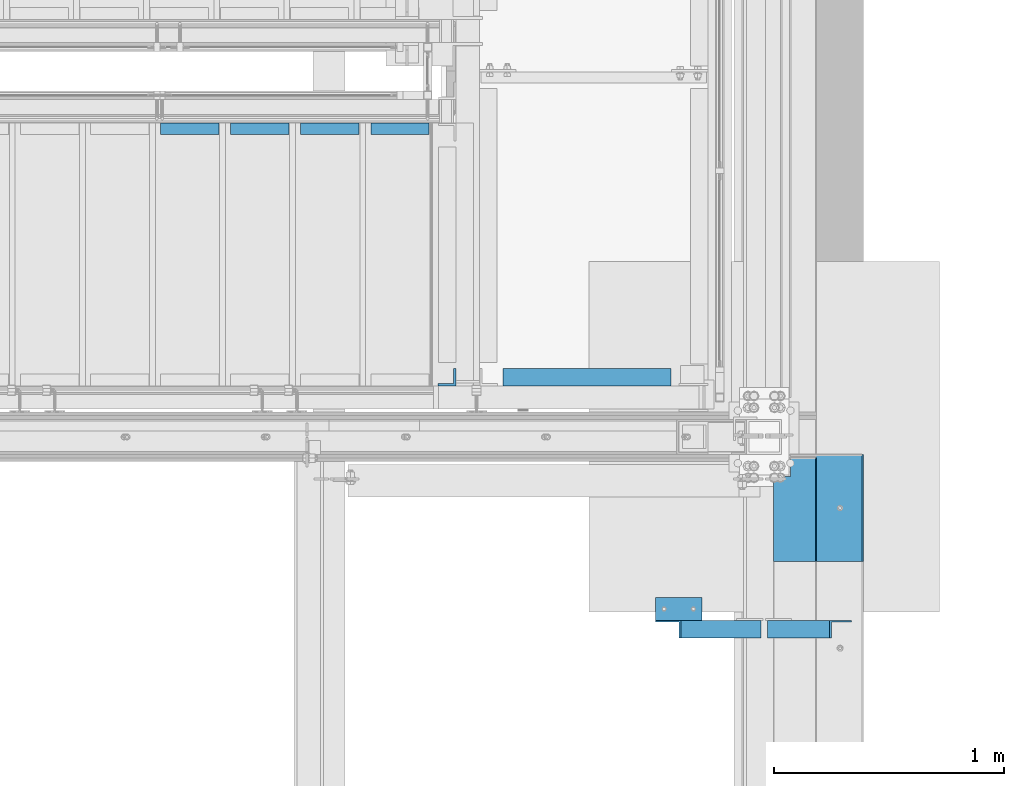
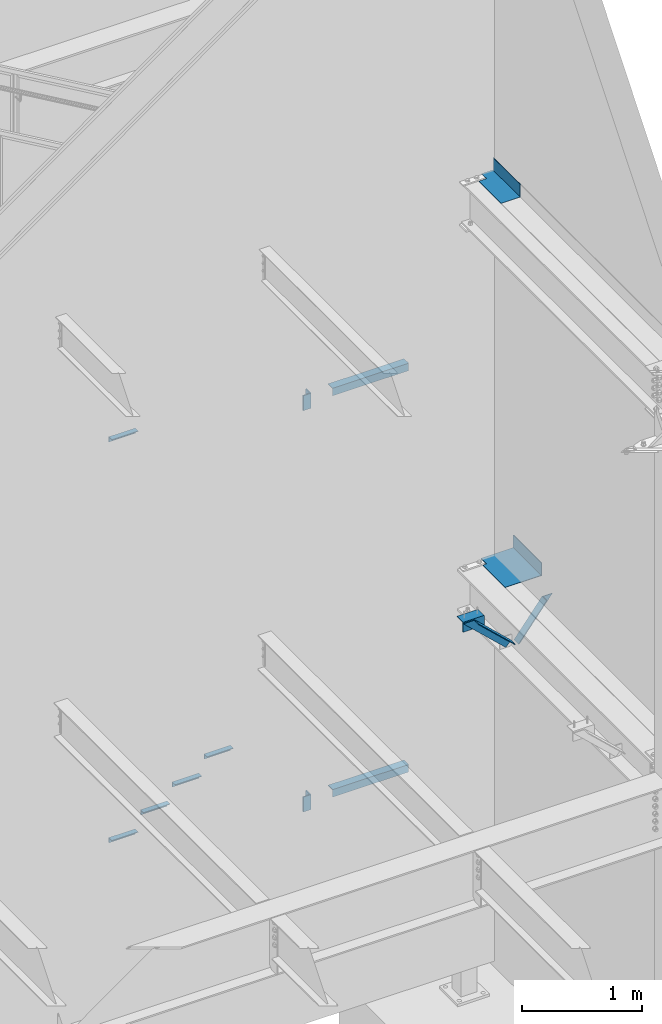
# One storey, part 918 of 1179: 12 beams, 2 members, 7 elements without a shape of their own.
"""IFC2X3 building model written with IfcOpenShell, lengths in millimetres."""

from ifc_helpers import new_model, si_unit, frame, origin_with_axes, place, context, subcontext, project, spatial, faceted_brep, material, type_object, element, aggregate, save


model = new_model("IFC2X3")

# Units and contexts
model_context = context("Model", 3, precision=1e-05, world=origin_with_axes())
body_context = subcontext(model_context, "Body", "Model", "MODEL_VIEW")
ifc_project = project(units=[si_unit("LENGTHUNIT", "METRE", prefix="MILLI"), si_unit("AREAUNIT", "SQUARE_METRE"), si_unit("VOLUMEUNIT", "CUBIC_METRE"), si_unit("MASSUNIT", "GRAM", prefix="KILO"), si_unit("TIMEUNIT", "SECOND"), si_unit("PLANEANGLEUNIT", "RADIAN"), si_unit("SOLIDANGLEUNIT", "STERADIAN"), si_unit("THERMODYNAMICTEMPERATUREUNIT", "DEGREE_CELSIUS"), si_unit("LUMINOUSINTENSITYUNIT", "LUMEN")], contexts=[model_context])

# Site, building, storey
site_placement = place(None, origin_with_axes())
site = spatial("IfcSite", under=ifc_project, at=site_placement, CompositionType="ELEMENT")
building_placement = place(site_placement, origin_with_axes())
building = spatial("IfcBuilding", under=site, at=building_placement, Name="Undefined", CompositionType="ELEMENT")
storey_placement = place(building_placement, origin_with_axes())
storey = spatial("IfcBuildingStorey", under=building, at=storey_placement, Name="Undefined", CompositionType="ELEMENT", Elevation=0.0)

# Assembly, beam
assembly_1_placement = place(storey_placement, origin_with_axes())
assembly_1 = element("IfcElementAssembly", 1, at=assembly_1_placement, inside=storey, Name="STAIR", AssemblyPlace="NOTDEFINED", PredefinedType="RIGID_FRAME")
ifc_material = material(Name="STEEL/A36")
beam_type_1 = type_object("IfcBeamType", Name="L2X2X3/16", PredefinedType="NOTDEFINED")
beam_1_placement = place(assembly_1_placement, frame((21682.4130334544, 39325.5499999802, 5401.27030000019), z_axis=(0.0, -1.0, 0.0), x_axis=(1.0, 0.0, 0.0)))
beam_1 = element("IfcBeam", 2, at=beam_1_placement, type_object=beam_type_1, material=ifc_material, Name="ANGLE", ObjectType="L2X2X3/16", context=body_context, shape_type="Brep", body=[
    faceted_brep([(0.0, 25.3999999999996, -25.4000000000015), (0.0, 25.3999999999996, 25.4000000000015), (254.0, 25.3999999999996, 25.4000000000001), (254.0, 25.3999999999996, -25.4000000000001), (0.0, 20.6374999999998, 25.4000000000015), (254.0, 20.6374999999998, 25.4000000000001), (0.0, 20.6374999999998, -20.6374999999971), (254.0, 20.6374999999998, -20.6374999999998), (0.0, -25.3999999999996, -20.6374999999971), (254.0, -25.3999999999996, -20.6374999999998), (0.0, -25.3999999999996, -25.4000000000015), (254.0, -25.3999999999996, -25.4000000000001)], [[[0, 1, 2, 3]], [[1, 4, 5, 2]], [[4, 6, 7, 5]], [[6, 8, 9, 7]], [[8, 10, 11, 9]], [[10, 0, 3, 11]], [[5, 7, 9, 11, 3, 2]], [[10, 8, 6, 4, 1, 0]]]),
])

# Assembly, beams
assembly_2_placement = place(storey_placement, origin_with_axes())
assembly_2 = element("IfcElementAssembly", 3, at=assembly_2_placement, inside=storey, Name="STAIR", AssemblyPlace="NOTDEFINED", PredefinedType="RIGID_FRAME")
beam_2_placement = place(assembly_2_placement, frame((22292.06782724, 39325.5499999935, 1685.99113280075), z_axis=(0.0, -1.0, 0.0), x_axis=(1.0, 0.0, 0.0)))
beam_2 = element("IfcBeam", 4, at=beam_2_placement, type_object=beam_type_1, material=ifc_material, Name="ANGLE", ObjectType="L2X2X3/16", context=body_context, shape_type="Brep", body=[
    faceted_brep([(0.0, 25.3999999999996, -25.4000000000015), (0.0, 25.3999999999996, 25.4000000000015), (254.0, 25.3999999999996, 25.4000000000001), (254.0, 25.3999999999996, -25.4000000000001), (0.0, 20.6374999999998, 25.4000000000015), (254.0, 20.6374999999998, 25.4000000000001), (0.0, 20.6374999999998, -20.6374999999971), (254.0, 20.6374999999998, -20.6374999999998), (0.0, -25.3999999999996, -20.6374999999971), (254.0, -25.3999999999996, -20.6374999999998), (0.0, -25.3999999999996, -25.4000000000015), (254.0, -25.3999999999996, -25.4000000000001)], [[[0, 1, 2, 3]], [[1, 4, 5, 2]], [[4, 6, 7, 5]], [[6, 8, 9, 7]], [[8, 10, 11, 9]], [[10, 0, 3, 11]], [[5, 7, 9, 11, 3, 2]], [[10, 8, 6, 4, 1, 0]]]),
])
beam_3_placement = place(assembly_2_placement, frame((21987.2678272132, 39325.5499999948, 1509.51404952155), z_axis=(0.0, -1.0, 0.0), x_axis=(1.0, 0.0, 0.0)))
beam_3 = element("IfcBeam", 5, at=beam_3_placement, type_object=beam_type_1, material=ifc_material, Name="ANGLE", ObjectType="L2X2X3/16", context=body_context, shape_type="Brep", body=[
    faceted_brep([(0.0, 25.3999999999996, -25.4000000000015), (0.0, 25.3999999999996, 25.4000000000015), (254.0, 25.3999999999996, 25.4000000000001), (254.0, 25.3999999999996, -25.4000000000001), (0.0, 20.6374999999998, 25.4000000000015), (254.0, 20.6374999999998, 25.4000000000001), (0.0, 20.6374999999998, -20.6374999999971), (254.0, 20.6374999999998, -20.6374999999998), (0.0, -25.3999999999996, -20.6374999999971), (254.0, -25.3999999999996, -20.6374999999998), (0.0, -25.3999999999996, -25.4000000000015), (254.0, -25.3999999999996, -25.4000000000001)], [[[0, 1, 2, 3]], [[1, 4, 5, 2]], [[4, 6, 7, 5]], [[6, 8, 9, 7]], [[8, 10, 11, 9]], [[10, 0, 3, 11]], [[5, 7, 9, 11, 3, 2]], [[10, 8, 6, 4, 1, 0]]]),
])
beam_4_placement = place(assembly_2_placement, frame((21682.4678271865, 39325.5499999961, 1333.03696624235), z_axis=(0.0, -1.0, 0.0), x_axis=(1.0, 0.0, 0.0)))
beam_4 = element("IfcBeam", 6, at=beam_4_placement, type_object=beam_type_1, material=ifc_material, Name="ANGLE", ObjectType="L2X2X3/16", context=body_context, shape_type="Brep", body=[
    faceted_brep([(0.0, 25.3999999999996, -25.4000000000015), (0.0, 25.3999999999996, 25.4000000000015), (254.0, 25.3999999999996, 25.4000000000001), (254.0, 25.3999999999996, -25.4000000000001), (0.0, 20.6374999999998, 25.4000000000015), (254.0, 20.6374999999998, 25.4000000000001), (0.0, 20.6374999999998, -20.6374999999971), (254.0, 20.6374999999998, -20.6374999999998), (0.0, -25.3999999999996, -20.6374999999971), (254.0, -25.3999999999996, -20.6374999999998), (0.0, -25.3999999999996, -25.4000000000015), (254.0, -25.3999999999996, -25.4000000000001)], [[[0, 1, 2, 3]], [[1, 4, 5, 2]], [[4, 6, 7, 5]], [[6, 8, 9, 7]], [[8, 10, 11, 9]], [[10, 0, 3, 11]], [[5, 7, 9, 11, 3, 2]], [[10, 8, 6, 4, 1, 0]]]),
])
beam_5_placement = place(assembly_2_placement, frame((22596.8678272667, 39325.5499999922, 1862.46821607994), z_axis=(0.0, -1.0, 0.0), x_axis=(1.0, 0.0, 0.0)))
beam_5 = element("IfcBeam", 7, at=beam_5_placement, type_object=beam_type_1, material=ifc_material, Name="ANGLE", ObjectType="L2X2X3/16", context=body_context, shape_type="Brep", body=[
    faceted_brep([(0.0, 25.3999999999996, -25.4000000000015), (0.0, 25.3999999999996, 25.4000000000015), (254.0, 25.3999999999996, 25.4000000000001), (254.0, 25.3999999999996, -25.4000000000001), (0.0, 20.6374999999998, 25.4000000000015), (254.0, 20.6374999999998, 25.4000000000001), (0.0, 20.6374999999998, -20.6374999999971), (254.0, 20.6374999999998, -20.6374999999998), (0.0, -25.3999999999996, -20.6374999999971), (254.0, -25.3999999999996, -20.6374999999998), (0.0, -25.3999999999996, -25.4000000000015), (254.0, -25.3999999999996, -25.4000000000001)], [[[0, 1, 2, 3]], [[1, 4, 5, 2]], [[4, 6, 7, 5]], [[6, 8, 9, 7]], [[8, 10, 11, 9]], [[10, 0, 3, 11]], [[5, 7, 9, 11, 3, 2]], [[10, 8, 6, 4, 1, 0]]]),
])

# Beam
beam_type_2 = type_object("IfcBeamType", Name="L3X3X3/8", PredefinedType="NOTDEFINED")
beam_6_placement = place(assembly_1_placement, frame((22928.2624999835, 38246.0499999749, 6112.47000099708), z_axis=(-1.0, 0.0, 0.0), x_axis=(0.0, 0.0, -1.0)))
beam_6 = element("IfcBeam", 8, at=beam_6_placement, type_object=beam_type_2, material=ifc_material, Name="ANGLE", ObjectType="L3X3X3/8", context=body_context, shape_type="Brep", body=[
    faceted_brep([(0.0, 38.0999999999985, -38.0999999999999), (0.0, 38.0999999999985, 38.0999999999999), (152.400000000001, 38.0999999999985, 38.0999999999999), (152.400000000001, 38.0999999999985, -38.0999999999999), (0.0, 28.5750000000007, 38.0999999999999), (152.400000000001, 28.5750000000007, 38.0999999999999), (0.0, 28.5750000000007, -28.575), (152.400000000001, 28.5750000000007, -28.575), (0.0, -38.0999999999985, -28.575), (152.400000000001, -38.0999999999985, -28.575), (0.0, -38.0999999999985, -38.0999999999999), (152.400000000001, -38.0999999999985, -38.0999999999999)], [[[0, 1, 2, 3]], [[1, 4, 5, 2]], [[4, 6, 7, 5]], [[6, 8, 9, 7]], [[8, 10, 11, 9]], [[10, 0, 3, 11]], [[5, 7, 9, 11, 3, 2]], [[10, 8, 6, 4, 1, 0]]]),
])

beam_7_placement = place(assembly_2_placement, frame((22928.2625003381, 38246.0499999749, 2038.945312), z_axis=(-1.0, 0.0, 0.0), x_axis=(0.0, 0.0, -1.0)))
beam_7 = element("IfcBeam", 9, at=beam_7_placement, type_object=beam_type_2, material=ifc_material, Name="ANGLE", ObjectType="L3X3X3/8", context=body_context, shape_type="Brep", body=[
    faceted_brep([(0.0, 38.0999999999985, -38.0999999999999), (0.0, 38.0999999999985, 38.0999999999999), (152.400000000001, 38.0999999999985, 38.0999999999999), (152.400000000001, 38.0999999999985, -38.0999999999999), (0.0, 28.5750000000007, 38.0999999999999), (152.400000000001, 28.5750000000007, 38.0999999999999), (0.0, 28.5750000000007, -28.575), (152.400000000001, 28.5750000000007, -28.575), (0.0, -38.0999999999985, -28.575), (152.400000000001, -38.0999999999985, -28.575), (0.0, -38.0999999999985, -38.0999999999999), (152.400000000001, -38.0999999999985, -38.0999999999999)], [[[0, 1, 2, 3]], [[1, 4, 5, 2]], [[4, 6, 7, 5]], [[6, 8, 9, 7]], [[8, 10, 11, 9]], [[10, 0, 3, 11]], [[5, 7, 9, 11, 3, 2]], [[10, 8, 6, 4, 1, 0]]]),
])

beam_type_3 = type_object("IfcBeamType", Name="L3X3X1/4", PredefinedType="NOTDEFINED")
beam_8_placement = place(assembly_1_placement, frame((23172.7374999277, 38246.0500000229, 6051.55), z_axis=(0.0, 0.0, -1.0), x_axis=(1.0, 0.0, 0.0)))
beam_8 = element("IfcBeam", 10, at=beam_8_placement, type_object=beam_type_3, material=ifc_material, Name="ANGLE", ObjectType="L3X3X1/4", context=body_context, shape_type="Brep", body=[
    faceted_brep([(0.0, 38.0999999999985, -38.0999999999999), (0.0, 38.0999999999985, 38.0999999999999), (729.059375016303, 38.0999999999985, 38.1000000000004), (729.059375016303, 38.0999999999985, -38.1000000000004), (0.0, 31.75, 38.1000000000004), (729.059375016303, 31.75, 38.1000000000004), (0.0, 31.75, -31.75), (729.059375016303, 31.75, -31.75), (0.0, -38.0999999999985, -31.75), (729.059375016303, -38.0999999999985, -31.75), (0.0, -38.0999999999985, -38.0999999999999), (729.059375016303, -38.0999999999985, -38.1000000000004)], [[[0, 1, 2, 3]], [[1, 4, 5, 2]], [[4, 6, 7, 5]], [[6, 8, 9, 7]], [[8, 10, 11, 9]], [[10, 0, 3, 11]], [[5, 7, 9, 11, 3, 2]], [[10, 8, 6, 4, 1, 0]]]),
])

aggregate(assembly_1, [beam_8, beam_6, beam_1])

beam_9_placement = place(assembly_2_placement, frame((23172.737500342, 38246.0499999749, 1978.025), z_axis=(0.0, 0.0, -1.0), x_axis=(1.0, 0.0, 0.0)))
beam_9 = element("IfcBeam", 11, at=beam_9_placement, type_object=beam_type_3, material=ifc_material, Name="ANGLE", ObjectType="L3X3X1/4", context=body_context, shape_type="Brep", body=[
    faceted_brep([(0.0, 38.0999999999985, -38.0999999999999), (0.0, 38.0999999999985, 38.0999999999999), (729.059375016303, 38.0999999999985, 38.1000000000004), (729.059375016303, 38.0999999999985, -38.1000000000004), (0.0, 31.75, 38.1000000000004), (729.059375016303, 31.75, 38.1000000000004), (0.0, 31.75, -31.75), (729.059375016303, 31.75, -31.75), (0.0, -38.0999999999985, -31.75), (729.059375016303, -38.0999999999985, -31.75), (0.0, -38.0999999999985, -38.0999999999999), (729.059375016303, -38.0999999999985, -38.1000000000004)], [[[0, 1, 2, 3]], [[1, 4, 5, 2]], [[4, 6, 7, 5]], [[6, 8, 9, 7]], [[8, 10, 11, 9]], [[10, 0, 3, 11]], [[5, 7, 9, 11, 3, 2]], [[10, 8, 6, 4, 1, 0]]]),
])

aggregate(assembly_2, [beam_9, beam_7, beam_2, beam_3, beam_4, beam_5])

# Assembly, member
assembly_3_placement = place(storey_placement, origin_with_axes())
assembly_3 = element("IfcElementAssembly", 12, at=assembly_3_placement, inside=storey, Name="ANGLE", AssemblyPlace="NOTDEFINED", PredefinedType="RIGID_FRAME")
member_type = type_object("IfcMemberType", Name="L3X3X1/4", PredefinedType="NOTDEFINED")
member_1_placement = place(assembly_3_placement, frame((23812.1150890972, 37148.29375, 4162.88757791506), z_axis=(0.0, -1.0, 0.0), x_axis=(0.729484494811633, 0.0, -0.683997347823379)))
member_1 = element("IfcMember", 13, at=member_1_placement, type_object=member_type, material=ifc_material, Name="ANGLE", ObjectType="L3X3X1/4", context=body_context, shape_type="Brep", body=[
    faceted_brep([(148.072119708857, 38.1000000000204, -38.0999999999985), (148.072119708857, 38.1000000000204, 38.0999999999985), (623.824460863128, 38.1000000000349, 38.0999999999985), (623.824460863128, 38.1000000000349, -38.0999999999985), (141.299832423247, 31.7500000000182, 38.0999999999985), (623.824460863128, 31.7500000000291, 38.0999999999985), (141.299832423247, 31.7500000000182, -31.75), (623.824460863128, 31.7500000000291, -31.75), (66.8046722815307, -38.1000000000095, -31.75), (623.824460863132, -38.0999999999913, -31.75), (66.8046722815307, -38.1000000000095, -38.0999999999985), (623.824460863132, -38.0999999999913, -38.0999999999985)], [[[0, 1, 2, 3]], [[1, 4, 5, 2]], [[4, 6, 7, 5]], [[6, 8, 9, 7]], [[8, 10, 11, 9]], [[10, 0, 3, 11]], [[5, 7, 9, 11, 3, 2]], [[10, 8, 6, 4, 1, 0]]]),
])
aggregate(assembly_3, [member_1])

assembly_4_placement = place(storey_placement, origin_with_axes())
assembly_4 = element("IfcElementAssembly", 14, at=assembly_4_placement, inside=storey, Name="ANGLE", AssemblyPlace="NOTDEFINED", PredefinedType="RIGID_FRAME")
member_2_placement = place(assembly_4_placement, frame((24352.3014298031, 37148.29375, 3731.6636484264), z_axis=(0.0, -1.0, 0.0), x_axis=(0.614083067285056, 0.0, 0.789241399366365)))
member_2 = element("IfcMember", 15, at=member_2_placement, type_object=member_type, material=ifc_material, Name="ANGLE", ObjectType="L3X3X1/4", context=body_context, shape_type="Brep", body=[
    faceted_brep([(0.0, 38.0999999999985, -38.0999999999999), (0.0, 38.0999999999985, 38.0999999999999), (439.713105507173, 38.1000000000386, 38.0999999999985), (439.713105507173, 38.1000000000386, -38.0999999999985), (0.0, 31.75, 38.1000000000004), (444.653834009747, 31.7500000000473, 38.0999999999985), (0.0, 31.75, -31.75), (444.653834009747, 31.7500000000473, -31.75), (0.0, -38.0999999999985, -31.75), (499.001847538042, -38.0999999998749, -31.75), (0.0, -38.0999999999985, -38.0999999999999), (499.001847538042, -38.0999999998749, -38.0999999999985)], [[[0, 1, 2, 3]], [[1, 4, 5, 2]], [[4, 6, 7, 5]], [[6, 8, 9, 7]], [[8, 10, 11, 9]], [[10, 0, 3, 11]], [[5, 7, 9, 11, 3, 2]], [[10, 8, 6, 4, 1, 0]]]),
])
aggregate(assembly_4, [member_2])

# Assembly, beam
assembly_5_placement = place(storey_placement, origin_with_axes())
assembly_5 = element("IfcElementAssembly", 16, at=assembly_5_placement, inside=storey, Name="ANGLE", AssemblyPlace="NOTDEFINED", PredefinedType="RIGID_FRAME")
beam_type_4 = type_object("IfcBeamType", Name="L4X4X1/4", PredefinedType="NOTDEFINED")
beam_10_placement = place(assembly_5_placement, frame((23834.8036446584, 37237.19375, 4051.3), z_axis=(0.0, 0.0, -1.0), x_axis=(1.0, 0.0, 0.0)))
beam_10 = element("IfcBeam", 17, at=beam_10_placement, type_object=beam_type_4, material=ifc_material, Name="ANGLE", ObjectType="L4X4X1/4", context=body_context, shape_type="Brep", body=[
    faceted_brep([(1.90993887372315e-11, 50.8000000000002, -50.8000000000002), (1.90993887372315e-11, 50.8000000000002, 50.8000000000002), (203.200000000001, 50.7999999999993, 50.8000000000002), (203.200000000001, 50.7999999999993, -50.8000000000002), (0.0, 44.4500000000007, 50.8000000000002), (203.200000000001, 44.4500000000007, 50.8000000000002), (0.0, 44.4500000000007, -44.4499999999998), (203.200000000001, 44.4500000000007, -44.4499999999998), (0.0, -50.7999999999993, -44.4499999999998), (203.200000000001, -50.7999999999993, -44.4499999999998), (-1.81898940354586e-11, -50.7999999999997, -50.8000000000002), (203.200000000001, -50.7999999999993, -50.8000000000002)], [[[0, 1, 2, 3]], [[1, 4, 5, 2]], [[4, 6, 7, 5]], [[6, 8, 9, 7]], [[8, 10, 11, 9]], [[10, 0, 3, 11]], [[5, 7, 9, 11, 3, 2]], [[10, 8, 6, 4, 1, 0]]]),
])
aggregate(assembly_5, [beam_10])

assembly_6_placement = place(storey_placement, origin_with_axes())
assembly_6 = element("IfcElementAssembly", 18, at=assembly_6_placement, inside=storey, Name="BEAM", AssemblyPlace="NOTDEFINED", PredefinedType="RIGID_FRAME")
beam_type_5 = type_object("IfcBeamType", PredefinedType="NOTDEFINED")
beam_11_placement = place(assembly_6_placement, frame((24347.4874996686, 37669.7874996802, 8016.875), z_axis=(0.0, 1.0, 0.0), x_axis=(1.0, 0.0, 0.0)))
beam_11 = element("IfcBeam", 19, at=beam_11_placement, type_object=beam_type_5, material=ifc_material, Name="BENT_PLATE", context=body_context, shape_type="Brep", body=[
    faceted_brep([(74.6124943107825, -3.17499997709365, 144.462500170514), (74.6124945139854, 3.17500002290672, 144.462500170514), (-1.09503162093461e-09, 3.17499999999927, 144.462500319787), (8.51287040859461e-10, -3.17500000000109, 144.462500319787), (74.6124945496776, -3.17499997709365, 227.01250000007), (74.6124947528806, 3.17500002290672, 227.01250000007), (182.562494038448, -3.17499994394984, -227.012499999844), (1.17870513349771e-09, -3.17500000000109, -227.012499999997), (-7.67613528296351e-10, 3.17499999999927, -227.012499999997), (188.912494241642, 3.17500005799957, -227.01249999983), (188.912489974678, -130.175012170228, -227.01249999983), (182.56248997468, -130.175011967039, -227.012499999844), (188.912494241238, 3.17500005799957, 227.012500000164), (188.912489974278, -130.175012170228, 227.012500000164), (182.562489974276, -130.175011967039, 227.012500000157), (182.562494038048, -3.17499994394984, 227.012500000157)], [[[0, 1, 2, 3]], [[4, 5, 1, 0]], [[6, 7, 8, 9, 10, 11]], [[9, 12, 13, 10]], [[14, 11, 10, 13]], [[15, 6, 11, 14]], [[3, 7, 6, 15, 4, 0]], [[8, 7, 3, 2]], [[12, 9, 8, 2, 1, 5]], [[15, 14, 13, 12, 5, 4]]]),
])
aggregate(assembly_6, [beam_11])

assembly_7_placement = place(storey_placement, origin_with_axes())
assembly_7 = element("IfcElementAssembly", 20, at=assembly_7_placement, inside=storey, Name="BEAM", AssemblyPlace="NOTDEFINED", PredefinedType="RIGID_FRAME")
beam_type_6 = type_object("IfcBeamType", PredefinedType="NOTDEFINED")
beam_12_placement = place(assembly_7_placement, frame((24387.175012207, 37676.1375, 4105.275), z_axis=(0.0, -1.0, 0.0), x_axis=(1.0, 0.0, 0.0)))
beam_12 = element("IfcBeam", 21, at=beam_12_placement, type_object=beam_type_6, material=ifc_material, Name="BENT_PLATE", context=body_context, shape_type="Brep", body=[
    faceted_brep([(34.9249816894517, -3.17500000000018, -138.112500000003), (34.9249816894517, 3.17500000000018, -138.112500000003), (34.9249816894517, 3.17500000000018, -233.362500000003), (34.9249816894517, -3.17500000000018, -233.362500000003), (0.0, -3.17500000000018, -138.112500000003), (0.0, 3.17500000000018, -138.112500000003), (346.07498779297, 3.17500000000109, 233.362500000003), (0.0, 3.17500000000018, 233.362500000003), (0.0, -3.17500000000018, 233.362500000003), (352.424987792969, -3.17499999999927, 233.362500000003), (352.424987792969, 130.175006103515, 233.362500000003), (346.07498779297, 130.175006103515, 233.362500000003), (346.07498779297, 3.17500000000109, -233.362500000003), (346.07498779297, 130.175006103515, -233.362500000003), (352.424987792969, 130.175006103515, -233.362500000003), (352.424987792969, -3.17499999999927, -233.362500000003)], [[[0, 1, 2, 3]], [[4, 5, 1, 0]], [[6, 7, 8, 9, 10, 11]], [[12, 6, 11, 13]], [[10, 14, 13, 11]], [[9, 15, 14, 10]], [[12, 13, 14, 15, 3, 2]], [[7, 6, 12, 2, 1, 5]], [[8, 7, 5, 4]], [[15, 9, 8, 4, 0, 3]]]),
])
aggregate(assembly_7, [beam_12])

save(model, "model.ifc")
